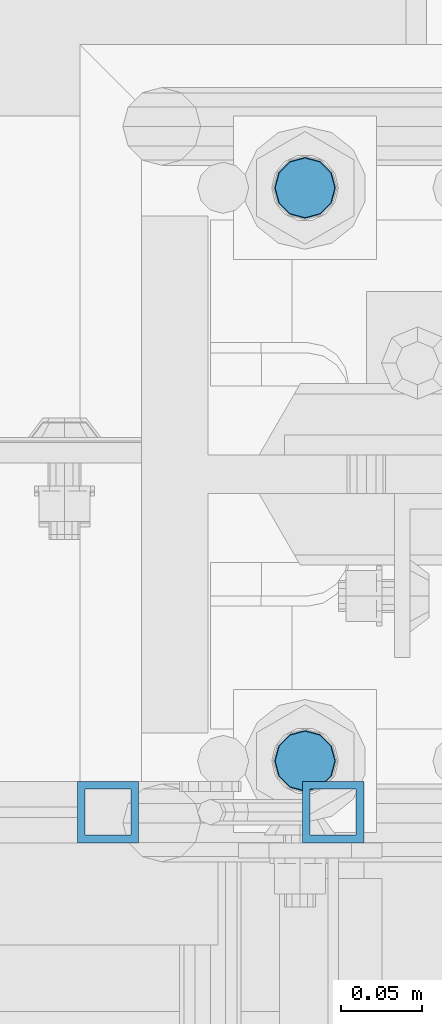
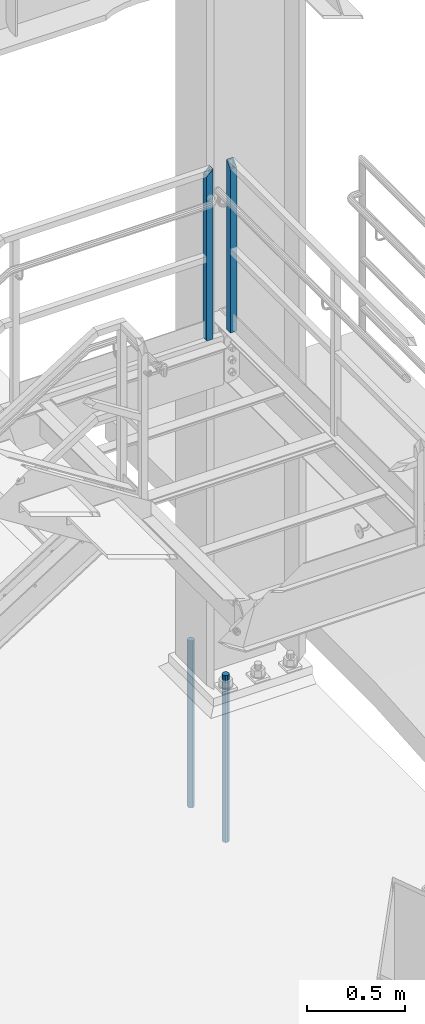
# One storey, part 650 of 1876: 4 columns, 3 elements without a shape of their own.
"""IFC2X3 building model written with IfcOpenShell, lengths in millimetres."""

from ifc_helpers import new_model, si_unit, frame, origin_with_axes, place, context, subcontext, project, spatial, faceted_brep, material, type_object, element, aggregate, save


model = new_model("IFC2X3")

# Units and contexts
model_context = context("Model", 3, precision=1e-05, world=origin_with_axes())
body_context = subcontext(model_context, "Body", "Model", "MODEL_VIEW")
ifc_project = project(units=[si_unit("LENGTHUNIT", "METRE", prefix="MILLI"), si_unit("AREAUNIT", "SQUARE_METRE"), si_unit("VOLUMEUNIT", "CUBIC_METRE"), si_unit("MASSUNIT", "GRAM", prefix="KILO"), si_unit("TIMEUNIT", "SECOND"), si_unit("PLANEANGLEUNIT", "RADIAN"), si_unit("SOLIDANGLEUNIT", "STERADIAN"), si_unit("THERMODYNAMICTEMPERATUREUNIT", "DEGREE_CELSIUS"), si_unit("LUMINOUSINTENSITYUNIT", "LUMEN")], contexts=[model_context])

# Site, building, storey
site_placement = place(None, origin_with_axes())
site = spatial("IfcSite", under=ifc_project, at=site_placement, CompositionType="ELEMENT")
building_placement = place(site_placement, origin_with_axes())
building = spatial("IfcBuilding", under=site, at=building_placement, Name="Undefined", CompositionType="ELEMENT")
storey_placement = place(building_placement, origin_with_axes())
storey = spatial("IfcBuildingStorey", under=building, at=storey_placement, Name="Undefined", CompositionType="ELEMENT", Elevation=0.0)

# Assembly, column
assembly_1_placement = place(storey_placement, origin_with_axes())
assembly_1 = element("IfcElementAssembly", 1, at=assembly_1_placement, inside=storey, Name="RAIL", AssemblyPlace="NOTDEFINED", PredefinedType="RIGID_FRAME")
ifc_material_1 = material()
column_type_1 = type_object("IfcColumnType", Name="HSS1-1/2X1-1/2X3/16", PredefinedType="NOTDEFINED")
column_1_placement = place(assembly_1_placement, frame((7446.9625, -4781.5500012144, 2330.45), z_axis=(0.0, -1.0, 0.0), x_axis=(0.0, 0.0, 1.0)))
column_1 = element("IfcColumn", 2, at=column_1_placement, type_object=column_type_1, material=ifc_material_1, Name="POST", ObjectType="HSS1-1/2X1-1/2X3/16", context=body_context, shape_type="Brep", body=[
    faceted_brep([(0.0, 14.2874994260001, -14.2874994260001), (0.0, -14.2874994260001, -14.2874994260001), (1055.687499426, -14.2874994260001, -14.2874994260001), (1055.687499426, 14.2874994260001, -14.2874994260001), (0.0, -14.2874994260001, 14.2874994260001), (1027.112500574, -14.2874994260001, 14.2874994260001), (0.0, 14.2874994260001, 14.2874994260001), (1027.112500574, 14.2874994260001, 14.2874994260001), (0.0, 19.0499992349996, -19.0499992350001), (0.0, 19.0499992349996, 19.0499992349996), (1022.350000765, 19.0499992349996, 19.0499992349996), (1060.449999235, 19.0499992349996, -19.0499992349996), (0.0, -19.0499992349996, 19.0499992349996), (1022.350000765, -19.0499992349996, 19.0499992349996), (0.0, -19.0499992349996, -19.0499992350001), (1060.449999235, -19.0499992349996, -19.0499992349996)], [[[0, 1, 2, 3]], [[1, 4, 5, 2]], [[4, 6, 7, 5]], [[6, 0, 3, 7]], [[8, 9, 10, 11]], [[9, 12, 13, 10]], [[12, 14, 15, 13]], [[14, 8, 11, 15]], [[13, 15, 11, 10], [5, 7, 3, 2]], [[14, 12, 9, 8], [6, 4, 1, 0]]]),
])
aggregate(assembly_1, [column_1])

assembly_2_placement = place(storey_placement, origin_with_axes())
assembly_2 = element("IfcElementAssembly", 3, at=assembly_2_placement, inside=storey, Name="RAIL", AssemblyPlace="NOTDEFINED", PredefinedType="RIGID_FRAME")
column_2_placement = place(assembly_2_placement, frame((7307.262500012, -4781.55000114554, 2329.68362061127), z_axis=(-1.0, 0.0, 0.0), x_axis=(0.0, 0.0, 1.0)))
column_2 = element("IfcColumn", 4, at=column_2_placement, type_object=column_type_1, material=ifc_material_1, Name="POST", ObjectType="HSS1-1/2X1-1/2X3/16", context=body_context, shape_type="Brep", body=[
    faceted_brep([(0.0, 14.2874994260001, -14.2874994260001), (0.0, -14.2874994260001, -14.2874994260001), (1055.687499426, -14.2874994260001, -14.2874994260001), (1055.687499426, 14.2874994260001, -14.2874994260001), (0.0, -14.2874994260001, 14.2874994260001), (1027.112500574, -14.2874994260001, 14.2874994260001), (0.0, 14.2874994260001, 14.2874994260001), (1027.112500574, 14.2874994260001, 14.2874994260001), (0.0, 19.0499992349996, -19.0499992350001), (0.0, 19.0499992349996, 19.0499992349996), (1022.350000765, 19.0499992349996, 19.0499992349996), (1060.449999235, 19.0499992349996, -19.0499992349996), (0.0, -19.0499992349996, 19.0499992349996), (1022.350000765, -19.0499992349996, 19.0499992349996), (0.0, -19.0499992349996, -19.0499992350001), (1060.449999235, -19.0499992349996, -19.0499992349996)], [[[0, 1, 2, 3]], [[1, 4, 5, 2]], [[4, 6, 7, 5]], [[6, 0, 3, 7]], [[8, 9, 10, 11]], [[9, 12, 13, 10]], [[12, 14, 15, 13]], [[14, 8, 11, 15]], [[13, 15, 11, 10], [5, 7, 3, 2]], [[14, 12, 9, 8], [6, 4, 1, 0]]]),
])
aggregate(assembly_2, [column_2])

# Assembly, columns
assembly_3_placement = place(storey_placement, origin_with_axes())
assembly_3 = element("IfcElementAssembly", 5, at=assembly_3_placement, inside=storey, Name="TEMPLATE", AssemblyPlace="NOTDEFINED", PredefinedType="RIGID_FRAME")
ifc_material_2 = material(Name="STEEL/F1554-GR.105")
column_type_2 = type_object("IfcColumnType", PredefinedType="NOTDEFINED")
column_3_placement = place(assembly_3_placement, frame((7429.5, -4749.8, 0.0), z_axis=(1.0, 0.0, 0.0), x_axis=(0.0, 0.0, -1.0)))
column_3 = element("IfcColumn", 6, at=column_3_placement, type_object=column_type_2, material=ifc_material_2, Name="ANCHOR_BOLTS", context=body_context, shape_type="Brep", body=[
    faceted_brep([(-177.8, -16.0214699700118, 9.25), (-177.8, -9.25, 16.0214699700121), (-177.8, 0.0, 18.5), (-177.8, 9.25, 16.0214699700121), (-177.8, 16.0214699700118, 9.25), (-177.8, 18.5, 0.0), (-177.8, 16.0214699700118, -9.25), (-177.8, 9.25, -16.0214699700121), (-177.8, 0.0, -18.5), (-177.8, -9.25, -16.0214699700121), (-177.8, -16.0214699700118, -9.25), (-177.8, -18.5, 0.0), (0.0, 18.5, 0.0), (0.0, 16.0214699700118, -9.25), (0.0, 9.25, -16.0214699700121), (0.0, 0.0, -18.5), (0.0, -9.25, -16.0214699700121), (0.0, -16.0214699700118, -9.25), (0.0, -18.5, 0.0), (0.0, -16.0214699700118, 9.25), (0.0, -9.25, 16.0214699700121), (0.0, 0.0, 18.5), (0.0, 9.25, 16.0214699700121), (0.0, 16.0214699700118, 9.25), (0.0, -16.4977839420935, 9.52500000000146), (0.0, -9.52500000000009, 16.4977839420935), (0.0, 0.0, 19.0499999999993), (0.0, 9.52500000000009, 16.4977839420935), (0.0, 16.4977839420935, 9.52500000000146), (-9.09494701772928e-13, 19.05, -1.81898940354586e-12), (0.0, 16.4977839420935, -9.52500000000146), (0.0, 9.52500000000009, -16.4977839420935), (0.0, 0.0, -19.05), (0.0, -9.52500000000009, -16.4977839420935), (0.0, -16.4977839420935, -9.52500000000146), (0.0, -19.0500000000002, 0.0), (685.799999999999, -19.05, 0.0), (685.799999999999, -16.4977839420936, 9.52500000000146), (685.799999999999, -9.52499999999998, 16.4977839420935), (685.799999999999, 0.0, 19.0499999999993), (685.799999999999, 9.52499999999998, 16.4977839420935), (685.799999999999, 16.4977839420936, 9.52500000000146), (685.799999999999, 19.05, 0.0), (685.799999999999, 16.4977839420936, -9.52500000000146), (685.799999999999, 9.52500000000003, -16.4977839420935), (685.799999999999, 0.0, -19.0499999999993), (685.799999999999, -9.52499999999998, -16.4977839420935), (685.799999999999, -16.4977839420936, -9.52500000000146), (685.8, -9.25, 16.0214699700121), (685.8, 0.0, 18.5), (685.8, 9.25, 16.0214699700121), (685.8, 16.0214699700118, 9.25), (685.8, 18.5, 0.0), (685.8, 16.0214699700118, -9.25), (685.8, 9.25, -16.0214699700121), (685.8, 0.0, -18.5), (685.8, -9.25, -16.0214699700121), (685.8, -16.0214699700118, -9.25), (685.8, -18.5, 0.0), (685.8, -16.0214699700118, 9.25), (863.6, -9.25, -16.0214699700121), (863.6, 0.0, -18.5), (863.6, 9.25, -16.0214699700121), (863.6, 16.0214699700118, -9.25), (863.6, 18.5, 0.0), (863.6, 16.0214699700118, 9.25), (863.6, 9.25, 16.0214699700121), (863.6, 0.0, 18.5), (863.6, -9.25, 16.0214699700121), (863.6, -16.0214699700118, 9.25), (863.6, -18.5, 0.0), (863.6, -16.0214699700118, -9.25)], [[[0, 1, 2, 3, 4, 5, 6, 7, 8, 9, 10, 11]], [[6, 5, 12, 13]], [[7, 6, 13, 14]], [[8, 7, 14, 15]], [[9, 8, 15, 16]], [[10, 9, 16, 17]], [[11, 10, 17, 18]], [[0, 11, 18, 19]], [[1, 0, 19, 20]], [[2, 1, 20, 21]], [[3, 2, 21, 22]], [[4, 3, 22, 23]], [[5, 4, 23, 12]], [[24, 25, 26, 27, 28, 29, 30, 31, 32, 33, 34, 35], [22, 21, 20, 19, 18, 17, 16, 15, 14, 13, 12, 23]], [[24, 35, 36, 37]], [[25, 24, 37, 38]], [[26, 25, 38, 39]], [[27, 26, 39, 40]], [[28, 27, 40, 41]], [[29, 28, 41, 42]], [[30, 29, 42, 43]], [[31, 30, 43, 44]], [[32, 31, 44, 45]], [[33, 32, 45, 46]], [[34, 33, 46, 47]], [[35, 34, 47, 36]], [[46, 45, 44, 43, 42, 41, 40, 39, 38, 37, 36, 47], [48, 49, 50, 51, 52, 53, 54, 55, 56, 57, 58, 59]], [[60, 61, 62, 63, 64, 65, 66, 67, 68, 69, 70, 71]], [[68, 67, 49, 48]], [[69, 68, 48, 59]], [[70, 69, 59, 58]], [[71, 70, 58, 57]], [[60, 71, 57, 56]], [[61, 60, 56, 55]], [[62, 61, 55, 54]], [[63, 62, 54, 53]], [[64, 63, 53, 52]], [[65, 64, 52, 51]], [[66, 65, 51, 50]], [[67, 66, 50, 49]]]),
])
column_4_placement = place(assembly_3_placement, frame((7429.5, -4394.2, 0.0), z_axis=(-1.0, 0.0, 0.0), x_axis=(0.0, 0.0, -1.0)))
column_4 = element("IfcColumn", 7, at=column_4_placement, type_object=column_type_2, material=ifc_material_2, Name="ANCHOR_BOLTS", context=body_context, shape_type="Brep", body=[
    faceted_brep([(-177.8, -16.0214699700118, 9.25), (-177.8, -9.25, 16.0214699700121), (-177.8, 0.0, 18.5), (-177.8, 9.25, 16.0214699700121), (-177.8, 16.0214699700118, 9.25), (-177.8, 18.5, 0.0), (-177.8, 16.0214699700118, -9.25), (-177.8, 9.25, -16.0214699700121), (-177.8, 0.0, -18.5), (-177.8, -9.25, -16.0214699700121), (-177.8, -16.0214699700118, -9.25), (-177.8, -18.5, 0.0), (0.0, 18.5, 0.0), (0.0, 16.0214699700118, -9.25), (0.0, 9.25, -16.0214699700121), (0.0, 0.0, -18.5), (0.0, -9.25, -16.0214699700121), (0.0, -16.0214699700118, -9.25), (0.0, -18.5, 0.0), (0.0, -16.0214699700118, 9.25), (0.0, -9.25, 16.0214699700121), (0.0, 0.0, 18.5), (0.0, 9.25, 16.0214699700121), (0.0, 16.0214699700118, 9.25), (0.0, -16.4977839420935, 9.52500000000146), (0.0, -9.52500000000009, 16.4977839420935), (0.0, 0.0, 19.0499999999993), (0.0, 9.52500000000009, 16.4977839420935), (0.0, 16.4977839420935, 9.52500000000146), (-9.09494701772928e-13, 19.05, -1.81898940354586e-12), (0.0, 16.4977839420935, -9.52500000000146), (0.0, 9.52500000000009, -16.4977839420935), (0.0, 0.0, -19.05), (0.0, -9.52500000000009, -16.4977839420935), (0.0, -16.4977839420935, -9.52500000000146), (0.0, -19.0500000000002, 0.0), (685.799999999999, -19.05, 0.0), (685.799999999999, -16.4977839420936, 9.52500000000146), (685.799999999999, -9.52499999999998, 16.4977839420935), (685.799999999999, 0.0, 19.0499999999993), (685.799999999999, 9.52499999999998, 16.4977839420935), (685.799999999999, 16.4977839420936, 9.52500000000146), (685.799999999999, 19.05, 0.0), (685.799999999999, 16.4977839420936, -9.52500000000146), (685.799999999999, 9.52500000000003, -16.4977839420935), (685.799999999999, 0.0, -19.0499999999993), (685.799999999999, -9.52499999999998, -16.4977839420935), (685.799999999999, -16.4977839420936, -9.52500000000146), (685.8, -9.25, 16.0214699700121), (685.8, 0.0, 18.5), (685.8, 9.25, 16.0214699700121), (685.8, 16.0214699700118, 9.25), (685.8, 18.5, 0.0), (685.8, 16.0214699700118, -9.25), (685.8, 9.25, -16.0214699700121), (685.8, 0.0, -18.5), (685.8, -9.25, -16.0214699700121), (685.8, -16.0214699700118, -9.25), (685.8, -18.5, 0.0), (685.8, -16.0214699700118, 9.25), (863.6, -9.25, -16.0214699700121), (863.6, 0.0, -18.5), (863.6, 9.25, -16.0214699700121), (863.6, 16.0214699700118, -9.25), (863.6, 18.5, 0.0), (863.6, 16.0214699700118, 9.25), (863.6, 9.25, 16.0214699700121), (863.6, 0.0, 18.5), (863.6, -9.25, 16.0214699700121), (863.6, -16.0214699700118, 9.25), (863.6, -18.5, 0.0), (863.6, -16.0214699700118, -9.25)], [[[0, 1, 2, 3, 4, 5, 6, 7, 8, 9, 10, 11]], [[6, 5, 12, 13]], [[7, 6, 13, 14]], [[8, 7, 14, 15]], [[9, 8, 15, 16]], [[10, 9, 16, 17]], [[11, 10, 17, 18]], [[0, 11, 18, 19]], [[1, 0, 19, 20]], [[2, 1, 20, 21]], [[3, 2, 21, 22]], [[4, 3, 22, 23]], [[5, 4, 23, 12]], [[24, 25, 26, 27, 28, 29, 30, 31, 32, 33, 34, 35], [22, 21, 20, 19, 18, 17, 16, 15, 14, 13, 12, 23]], [[24, 35, 36, 37]], [[25, 24, 37, 38]], [[26, 25, 38, 39]], [[27, 26, 39, 40]], [[28, 27, 40, 41]], [[29, 28, 41, 42]], [[30, 29, 42, 43]], [[31, 30, 43, 44]], [[32, 31, 44, 45]], [[33, 32, 45, 46]], [[34, 33, 46, 47]], [[35, 34, 47, 36]], [[46, 45, 44, 43, 42, 41, 40, 39, 38, 37, 36, 47], [48, 49, 50, 51, 52, 53, 54, 55, 56, 57, 58, 59]], [[60, 61, 62, 63, 64, 65, 66, 67, 68, 69, 70, 71]], [[68, 67, 49, 48]], [[69, 68, 48, 59]], [[70, 69, 59, 58]], [[71, 70, 58, 57]], [[60, 71, 57, 56]], [[61, 60, 56, 55]], [[62, 61, 55, 54]], [[63, 62, 54, 53]], [[64, 63, 53, 52]], [[65, 64, 52, 51]], [[66, 65, 51, 50]], [[67, 66, 50, 49]]]),
])
aggregate(assembly_3, [column_3, column_4])

save(model, "model.ifc")
